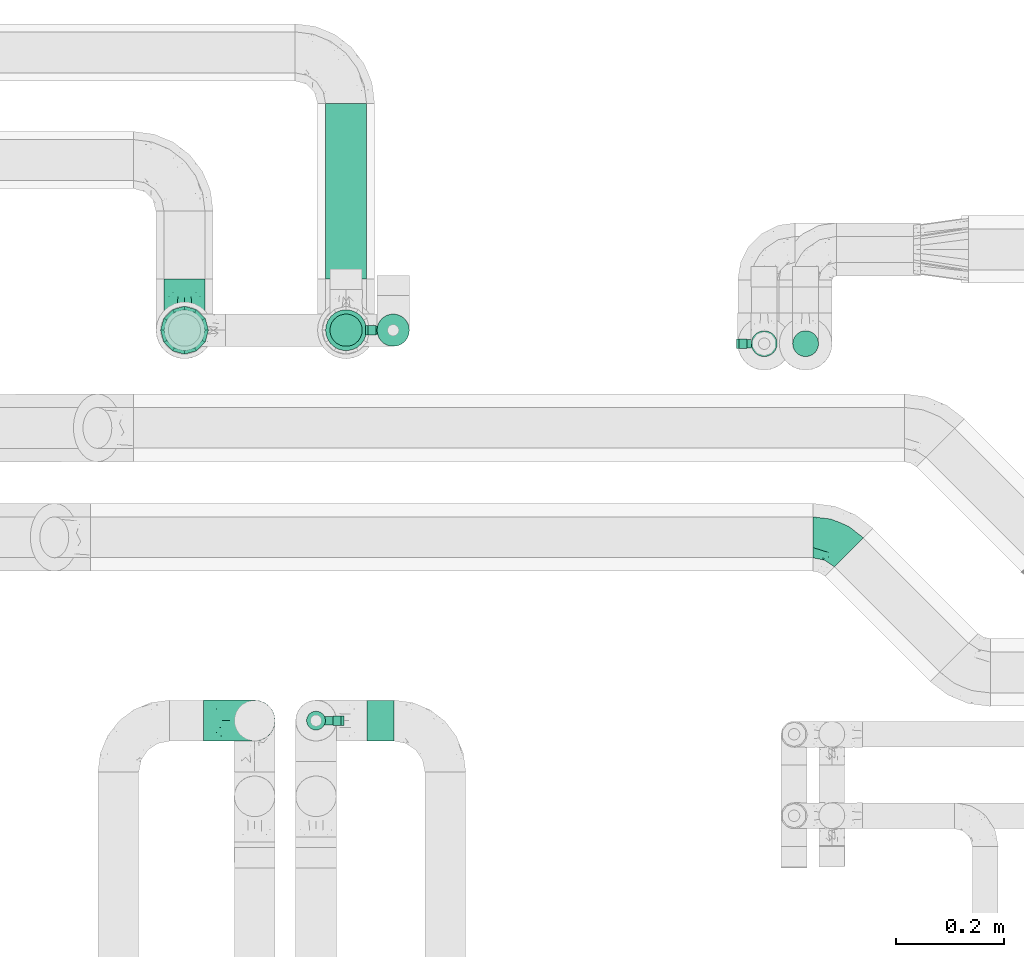
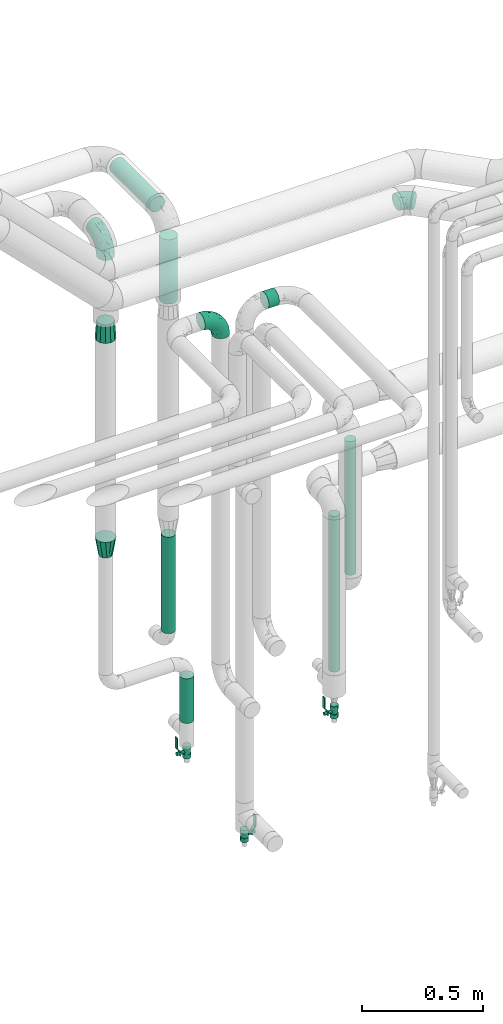
# One storey, part 680 of 824: 7 flow segments, 5 flow fittings, 3 flow controllers.
"""IFC2X3 building model written with IfcOpenShell, lengths in millimetres."""

from ifc_helpers import new_model, entity, si_unit, converted_unit, derived_unit, direction, frame, origin, origin_2d_with_axis, place, context, subcontext, project, spatial, polyline, circle, outline, extrude, faceted_brep, source, transform, mapped, material, material_list, type_object, type_shapes, element, save


model = new_model("IFC2X3")

# Units and contexts
model_context = context("Model", 3, precision=0.01, world=origin(), true_north=direction((6.12303176911189e-17, 1.0)))
body_context = subcontext(model_context, "Body", "Model", "MODEL_VIEW")
ifc_project = project(units=[si_unit("LENGTHUNIT", "METRE", prefix="MILLI"), si_unit("AREAUNIT", "SQUARE_METRE"), si_unit("VOLUMEUNIT", "CUBIC_METRE"), converted_unit("PLANEANGLEUNIT", "DEGREE", entity("IfcRatioMeasure", 0.0174532925199433), si_unit("PLANEANGLEUNIT", "RADIAN"), dimensions=[0, 0, 0, 0, 0, 0, 0]), si_unit("MASSUNIT", "GRAM", prefix="KILO"), derived_unit("MASSDENSITYUNIT", [(si_unit("MASSUNIT", "GRAM", prefix="KILO"), 1), (si_unit("LENGTHUNIT", "METRE"), -3)]), derived_unit("MOMENTOFINERTIAUNIT", [(si_unit("LENGTHUNIT", "METRE"), 4)]), si_unit("TIMEUNIT", "SECOND"), si_unit("FREQUENCYUNIT", "HERTZ"), si_unit("THERMODYNAMICTEMPERATUREUNIT", "DEGREE_CELSIUS"), derived_unit("THERMALTRANSMITTANCEUNIT", [(si_unit("MASSUNIT", "GRAM", prefix="KILO"), 1), (si_unit("THERMODYNAMICTEMPERATUREUNIT", "KELVIN"), -1), (si_unit("TIMEUNIT", "SECOND"), -3)]), derived_unit("VOLUMETRICFLOWRATEUNIT", [(si_unit("LENGTHUNIT", "METRE"), 3), (si_unit("TIMEUNIT", "SECOND"), -1)]), derived_unit("MASSFLOWRATEUNIT", [(si_unit("MASSUNIT", "GRAM", prefix="KILO"), 1), (si_unit("TIMEUNIT", "SECOND"), -1)]), derived_unit("ROTATIONALFREQUENCYUNIT", [(si_unit("TIMEUNIT", "SECOND"), -1)]), si_unit("ELECTRICCURRENTUNIT", "AMPERE"), si_unit("ELECTRICVOLTAGEUNIT", "VOLT"), si_unit("POWERUNIT", "WATT"), si_unit("FORCEUNIT", "NEWTON", prefix="KILO"), si_unit("ILLUMINANCEUNIT", "LUX"), si_unit("LUMINOUSFLUXUNIT", "LUMEN"), si_unit("LUMINOUSINTENSITYUNIT", "CANDELA"), derived_unit("USERDEFINED", [(si_unit("MASSUNIT", "GRAM", prefix="KILO"), -1), (si_unit("LENGTHUNIT", "METRE"), -2), (si_unit("TIMEUNIT", "SECOND"), 3), (si_unit("LUMINOUSFLUXUNIT", "LUMEN"), 1)]), derived_unit("LINEARVELOCITYUNIT", [(si_unit("LENGTHUNIT", "METRE"), 1), (si_unit("TIMEUNIT", "SECOND"), -1)]), si_unit("PRESSUREUNIT", "PASCAL"), derived_unit("USERDEFINED", [(si_unit("LENGTHUNIT", "METRE"), -2), (si_unit("MASSUNIT", "GRAM", prefix="KILO"), 1), (si_unit("TIMEUNIT", "SECOND"), -2)]), derived_unit("LINEARFORCEUNIT", [(si_unit("MASSUNIT", "GRAM", prefix="KILO"), 1), (si_unit("LENGTHUNIT", "METRE"), 1), (si_unit("TIMEUNIT", "SECOND"), -2), (si_unit("LENGTHUNIT", "METRE"), -1)]), derived_unit("PLANARFORCEUNIT", [(si_unit("MASSUNIT", "GRAM", prefix="KILO"), 1), (si_unit("LENGTHUNIT", "METRE"), 1), (si_unit("TIMEUNIT", "SECOND"), -2), (si_unit("LENGTHUNIT", "METRE"), -2)])], contexts=[model_context])

# Site, building, storey
site_placement = place(None, origin())
site = spatial("IfcSite", under=ifc_project, at=site_placement, CompositionType="ELEMENT")
building_placement = place(site_placement, origin())
building = spatial("IfcBuilding", under=site, at=building_placement, CompositionType="ELEMENT")
storey_placement = place(building_placement, frame((0.0, 0.0, 28200.0)))
storey = spatial("IfcBuildingStorey", under=building, at=storey_placement, CompositionType="ELEMENT", Elevation=28200.0)

# Flow segments
pipe_segment_type_1 = type_object("IfcPipeSegmentType", PredefinedType="NOTDEFINED")
flow_segment_1_placement = place(storey_placement, frame((46768.22, 19086.22, 2960.4)))
element("IfcFlowSegment", 1, at=flow_segment_1_placement, inside=storey, type_object=pipe_segment_type_1, context=body_context, shape_type="SweptSolid", body=[
    extrude(circle(Radius=38.0, at=origin_2d_with_axis()), frame((39.6, 0.0, 39.6), z_axis=(0.0, 1.0, 0.0), x_axis=(-1.0, 0.0, 0.0)), (0.0, 0.0, 1.0), 326.0116),
])
flow_segment_2_placement = place(storey_placement, frame((46768.22, 18951.63, 2580.0)))
element("IfcFlowSegment", 2, at=flow_segment_2_placement, inside=storey, type_object=pipe_segment_type_1, context=body_context, shape_type="SweptSolid", body=[
    extrude(circle(Radius=38.0, at=origin_2d_with_axis()), frame((39.6, 39.6, 0.0)), (0.0, 0.0, 1.0), 325.000000000017),
])
pipe_segment_type_2 = type_object("IfcPipeSegmentType", PredefinedType="NOTDEFINED")
flow_segment_3_placement = place(storey_placement, frame((46847.07, 18226.89, 2960.65)))
element("IfcFlowSegment", 3, at=flow_segment_3_placement, inside=storey, type_object=pipe_segment_type_2, context=body_context, shape_type="SweptSolid", body=[
    extrude(circle(Radius=37.75, at=origin_2d_with_axis()), frame((0.0, 39.35, 39.35), z_axis=(1.0, 0.0, 0.0), x_axis=(0.0, 1.0, 0.0)), (0.0, 0.0, 1.0), 50.000000000006),
])
flow_segment_4_placement = place(storey_placement, frame((47558.7, 18940.63, 457.0)))
element("IfcFlowSegment", 4, at=flow_segment_4_placement, inside=storey, type_object=pipe_segment_type_2, context=body_context, shape_type="SweptSolid", body=[
    extrude(circle(Radius=24.0, at=origin_2d_with_axis()), frame((25.6, 25.6, 0.0)), (0.0, 0.0, 1.0), 785.999999709128),
])
flow_segment_5_placement = place(storey_placement, frame((47635.58, 18940.63, 918.88)))
element("IfcFlowSegment", 5, at=flow_segment_5_placement, inside=storey, type_object=pipe_segment_type_2, context=body_context, shape_type="SweptSolid", body=[
    extrude(circle(Radius=24.0, at=origin_2d_with_axis()), frame((25.6, 25.6, 0.0), z_axis=(0.0, 0.0, 1.0), x_axis=(-1.0, 0.0, 0.0)), (0.0, 0.0, 1.0), 674.12499999997),
])
flow_segment_6_placement = place(storey_placement, frame((46776.22, 18959.63, 912.38)))
element("IfcFlowSegment", 6, at=flow_segment_6_placement, inside=storey, type_object=pipe_segment_type_2, context=body_context, shape_type="SweptSolid", body=[
    extrude(circle(Radius=30.0, at=origin_2d_with_axis()), frame((31.6, 31.6, 0.0), z_axis=(0.0, 0.0, 1.0), x_axis=(-1.0, 0.0, 0.0)), (0.0, 0.0, 1.0), 486.500000000002),
])
flow_segment_7_placement = place(storey_placement, frame((46863.72, 18959.63, 429.0)))
element("IfcFlowSegment", 7, at=flow_segment_7_placement, inside=storey, type_object=pipe_segment_type_2, context=body_context, shape_type="SweptSolid", body=[
    extrude(circle(Radius=30.0, at=origin_2d_with_axis()), frame((31.6, 31.6, 0.0)), (0.0, 0.0, 1.0), 224.999999999888),
])

# Flow controllers
ifc_material = material()
ifc_material_list = material_list([ifc_material, ifc_material, ifc_material, ifc_material, ifc_material])
valve_type = type_object("IfcValveType", PredefinedType="NOTDEFINED", material=ifc_material_list)
shared_shape_1 = source(origin(), body_context, "Body", "SweptSolid", [
    extrude(circle(Radius=17.5, at=origin_2d_with_axis()), frame((-30.5, 0.0, 0.0), z_axis=(1.0, 0.0, 0.0), x_axis=(0.0, 1.0, 0.0)), (0.0, 0.0, 1.0), 20.3333333333333),
    extrude(circle(Radius=16.0, at=origin_2d_with_axis()), frame((-10.17, 0.0, 0.0), z_axis=(1.0, 0.0, 0.0), x_axis=(0.0, 1.0, 0.0)), (0.0, 0.0, 1.0), 20.3333333333333),
    extrude(circle(Radius=17.5, at=origin_2d_with_axis()), frame((10.17, 0.0, 0.0), z_axis=(1.0, 0.0, 0.0), x_axis=(0.0, 1.0, 0.0)), (0.0, 0.0, 1.0), 20.3333333333333),
    extrude(outline(polyline([(-38.75, -5.0), (-38.75, -10.0), (-17.92, -10.0), (2.08, 5.0), (56.25, 5.0), (56.25, 10.0), (0.42, 10.0), (-19.58, -5.0), (-38.75, -5.0)])), frame((28.75, -8.75, 41.5), z_axis=(0.0, -1.0, 0.0), x_axis=(1.0, 0.0, 0.0)), (0.0, 0.0, -1.0), 17.5),
    extrude(circle(Radius=8.0, at=origin_2d_with_axis()), origin(), (0.0, 0.0, 1.0), 49.0),
])
type_shapes(valve_type, [shared_shape_1])
for number, where, z_axis, x_axis in (
    (8, (47584.3, 18966.22, 247.5), (-1.0, 0.0, 0.0), (0.0, 0.0, 1.0)),
    (9, (46895.32, 18991.22, 270.5), (-1.0, 0.0, 0.0), (0.0, 0.0, 1.0)),
    (10, (46752.07, 18266.24, 338.5), (1.0, 0.0, 0.0), (0.0, 0.0, 1.0)),
):
    element("IfcFlowController", number, at=place(storey_placement, frame(where, z_axis=z_axis, x_axis=x_axis)), inside=storey, type_object=valve_type, material=ifc_material, context=body_context, shape_type="MappedRepresentation", body=[
        mapped(shared_shape_1, transform((0.0, 0.0, 0.0), scale=1.0)),
    ])

# Flow fittings
pipe_fitting_type_1 = type_object("IfcPipeFittingType", PredefinedType="NOTDEFINED", material=ifc_material)
shared_shape_2 = source(origin(), body_context, "Body", "Brep", [
    faceted_brep([(-95.0, 19.02, -32.95), (-95.0, 9.85, -36.75), (-95.0, 0.0, -38.05), (-95.0, -9.85, -36.75), (-95.0, -19.03, -32.95), (-95.0, -26.91, -26.91), (-95.0, -32.95, -19.03), (-95.0, -36.75, -9.85), (-95.0, -38.05, 0.0), (-95.0, -36.75, 9.85), (-95.0, -32.95, 19.02), (-95.0, -26.91, 26.91), (-95.0, -19.03, 32.95), (-95.0, -9.85, 36.75), (-95.0, 0.0, 38.05), (-95.0, 9.85, 36.75), (-95.0, 19.02, 32.95), (-95.0, 26.91, 26.91), (-95.0, 32.95, 19.02), (-95.0, 36.75, 9.85), (-95.0, 38.05, 0.0), (-95.0, 36.75, -9.85), (-95.0, 32.95, -19.03), (-95.0, 26.91, -26.91), (0.0, 95.0, -38.05), (-9.85, 95.0, -36.75), (-19.02, 95.0, -32.95), (-26.91, 95.0, -26.91), (-32.95, 95.0, -19.03), (-36.75, 95.0, -9.85), (-38.05, 95.0, 0.0), (-36.75, 95.0, 9.85), (-32.95, 95.0, 19.02), (-26.91, 95.0, 26.91), (-19.02, 95.0, 32.95), (-9.85, 95.0, 36.75), (0.0, 95.0, 38.05), (9.85, 95.0, 36.75), (19.03, 95.0, 32.95), (26.91, 95.0, 26.91), (32.95, 95.0, 19.02), (36.75, 95.0, 9.85), (38.05, 95.0, 0.0), (36.75, 95.0, -9.85), (32.95, 95.0, -19.03), (26.91, 95.0, -26.91), (19.03, 95.0, -32.95), (9.85, 95.0, -36.75), (-7.99, -4.96, 6.3), (-0.92, 0.92, 0.0), (4.62, 8.1, 8.01), (-76.19, -35.57, 0.0), (-64.32, -32.32, 12.43), (20.51, 62.45, 28.68), (-60.56, -33.52, 0.0), (-70.4, -13.47, 34.42), (-39.61, -5.88, 32.32), (-49.6, 2.07, 37.1), (-70.34, -28.81, 21.71), (14.64, 40.81, 26.5), (5.88, 39.61, 32.32), (3.59, 20.77, 25.31), (-40.45, 68.06, 16.75), (-62.45, -20.51, 28.68), (-44.52, -26.87, 0.0), (-28.47, -20.22, 0.0), (-26.43, -17.83, 8.75), (-76.1, 39.63, 10.76), (-72.74, 37.58, 18.19), (-60.35, 46.18, 14.61), (-13.4, 13.4, 32.12), (-20.77, -3.59, 25.31), (-14.66, 81.47, 35.56), (-6.22, 71.26, 37.92), (-57.5, 42.48, 22.79), (-15.0, 34.74, 37.7), (-27.1, 12.08, 36.05), (-9.2, 28.81, 35.63), (-79.98, 23.7, 30.95), (-73.68, -4.3, 37.48), (-30.74, 21.67, 37.97), (-62.36, 47.59, 6.79), (-72.71, 32.83, 24.69), (-67.42, 7.02, 37.95), (-32.13, 75.27, 24.51), (-43.46, 51.47, 26.26), (-24.98, 73.15, 31.29), (20.59, 41.28, 19.85), (7.79, 16.09, 15.86), (-73.21, 42.39, 0.0), (-54.73, 54.73, 0.0), (-73.44, 15.79, 35.79), (-5.94, 4.32, 20.43), (28.81, 70.34, 21.71), (32.32, 64.32, 12.43), (-53.59, 26.2, 35.09), (-52.02, 19.31, 37.21), (21.38, 33.53, 10.34), (26.87, 44.52, 0.0), (-48.28, 12.14, 38.05), (4.3, 73.68, 37.48), (-44.08, -25.52, 12.79), (-41.28, -20.59, 19.85), (35.57, 76.19, 0.0), (-47.26, 54.3, 20.18), (-47.4, 61.99, 8.58), (-42.39, 73.21, 0.0), (-39.67, 78.86, 7.21), (-45.69, 36.84, 33.11), (-32.83, 50.13, 33.35), (13.47, 70.4, 34.42), (-18.25, 63.73, 36.07), (-40.63, -13.75, 27.22), (-16.63, 46.37, 37.95), (-53.47, 38.79, 28.59), (-26.07, 48.54, 36.15), (-34.51, 34.51, 36.86), (-2.07, 49.6, 37.1), (-22.79, -10.49, 19.23), (-61.73, 28.67, 31.87), (9.65, 14.7, 0.0), (20.22, 28.47, 0.0), (33.52, 60.56, 0.0), (-11.42, -5.44, 13.25), (-14.7, -9.65, 0.0), (-81.47, 14.66, -35.56), (-62.45, -20.51, -28.68), (-71.26, 6.22, -37.92), (-75.27, 32.13, -24.51), (-73.15, 24.98, -31.29), (13.47, 70.4, -34.42), (5.88, 39.61, -32.32), (-2.07, 49.6, -37.1), (-78.86, 39.67, -7.21), (-70.4, -13.47, -34.42), (-39.61, -5.88, -32.32), (-61.99, 47.4, -8.58), (32.32, 64.32, -12.43), (28.81, 70.34, -21.71), (-63.73, 18.25, -36.07), (-50.13, 32.83, -33.35), (4.3, 73.68, -37.48), (-7.02, 67.42, -37.95), (-39.63, 76.1, -10.76), (-46.18, 60.35, -14.61), (-47.59, 62.36, -6.79), (-64.32, -32.32, -12.43), (-26.2, 53.59, -35.09), (-15.79, 73.44, -35.79), (-19.31, 52.02, -37.21), (-37.58, 72.74, -18.19), (-70.34, -28.81, -21.71), (-42.48, 57.5, -22.79), (-38.79, 53.47, -28.59), (-51.47, 43.46, -26.26), (-32.83, 72.71, -24.69), (-46.37, 16.63, -37.95), (-73.68, -4.3, -37.48), (-41.28, -20.59, -19.85), (-44.08, -25.52, -12.79), (13.75, 40.63, -27.22), (20.51, 62.45, -28.68), (-68.06, 40.45, -16.75), (-54.3, 47.26, -20.18), (-12.14, 48.28, -38.05), (-21.67, 30.74, -37.97), (-36.84, 45.69, -33.11), (-11.42, -5.44, -13.25), (7.79, 16.09, -15.86), (4.62, 8.1, -8.01), (-23.7, 79.98, -30.95), (-26.43, -17.83, -8.75), (-7.99, -4.96, -6.3), (-40.81, -14.64, -26.5), (-20.77, -3.59, -25.31), (-34.74, 15.0, -37.7), (-12.08, 27.1, -36.05), (-28.81, 9.2, -35.63), (-22.79, -10.49, -19.23), (21.38, 33.53, -10.34), (20.59, 41.28, -19.85), (-48.54, 26.07, -36.15), (-49.6, 2.07, -37.1), (-13.4, 13.4, -32.12), (3.59, 20.77, -25.31), (-28.67, 61.73, -31.87), (-34.51, 34.51, -36.86), (-5.94, 4.32, -20.43)], [[[0, 1, 2, 3, 4, 5, 6, 7, 8, 9, 10, 11, 12, 13, 14, 15, 16, 17, 18, 19, 20, 21, 22, 23]], [[24, 25, 26, 27, 28, 29, 30, 31, 32, 33, 34, 35, 36, 37, 38, 39, 40, 41, 42, 43, 44, 45, 46, 47]], [[48, 49, 50]], [[51, 52, 9]], [[53, 39, 38]], [[9, 52, 10]], [[54, 52, 51]], [[55, 56, 57]], [[11, 10, 58]], [[59, 60, 61]], [[32, 31, 62]], [[63, 12, 11]], [[63, 55, 12]], [[64, 65, 66]], [[67, 68, 69]], [[70, 56, 71]], [[35, 72, 73]], [[69, 68, 74]], [[75, 76, 77]], [[16, 78, 17]], [[13, 79, 14]], [[76, 75, 80]], [[67, 69, 81]], [[18, 17, 82]], [[14, 79, 83]], [[20, 19, 67]], [[84, 85, 86]], [[87, 61, 88]], [[89, 81, 90]], [[18, 82, 68]], [[15, 91, 16]], [[14, 83, 15]], [[71, 92, 61]], [[17, 78, 82]], [[93, 87, 94]], [[95, 91, 96]], [[97, 98, 94]], [[86, 72, 34]], [[96, 99, 80]], [[37, 36, 100]], [[40, 39, 93]], [[40, 94, 41]], [[64, 66, 101]], [[93, 94, 40]], [[58, 102, 63]], [[94, 103, 41]], [[94, 87, 97]], [[104, 69, 74]], [[34, 33, 86]], [[105, 69, 104]], [[52, 58, 10]], [[106, 107, 30]], [[108, 109, 85]], [[105, 106, 90]], [[53, 110, 60]], [[86, 111, 72]], [[86, 109, 111]], [[33, 84, 86]], [[12, 55, 13]], [[112, 56, 63]], [[110, 38, 37]], [[34, 72, 35]], [[36, 35, 73]], [[111, 113, 73]], [[105, 107, 106]], [[110, 53, 38]], [[74, 114, 85]], [[91, 15, 83]], [[105, 90, 81]], [[107, 62, 31]], [[33, 32, 84]], [[115, 109, 116]], [[111, 115, 113]], [[100, 73, 117]], [[56, 55, 63]], [[79, 55, 57]], [[102, 118, 112]], [[56, 70, 76]], [[100, 110, 37]], [[117, 77, 60]], [[117, 60, 110]], [[60, 70, 61]], [[58, 52, 101]], [[63, 11, 58]], [[39, 53, 93]], [[87, 93, 53]], [[96, 91, 83]], [[78, 91, 119]], [[32, 62, 84]], [[84, 62, 104]], [[86, 85, 109]], [[85, 114, 108]], [[80, 113, 116]], [[117, 73, 113]], [[80, 116, 96]], [[80, 57, 76]], [[71, 112, 118]], [[61, 87, 59]], [[62, 107, 105]], [[97, 120, 121]], [[70, 71, 61]], [[71, 118, 92]], [[73, 100, 36]], [[110, 100, 117]], [[55, 79, 13]], [[83, 79, 57]], [[96, 83, 99]], [[116, 108, 95]], [[50, 97, 88]], [[97, 87, 88]], [[50, 49, 120]], [[122, 94, 98]], [[89, 20, 67]], [[105, 81, 69]], [[89, 67, 81]], [[68, 19, 18]], [[68, 67, 19]], [[74, 68, 82]], [[114, 82, 119]], [[74, 85, 104]], [[82, 114, 74]], [[114, 119, 108]], [[95, 108, 119]], [[116, 109, 108]], [[123, 48, 50]], [[97, 50, 120]], [[123, 50, 88]], [[91, 95, 119]], [[116, 95, 96]], [[84, 104, 85]], [[104, 62, 105]], [[83, 57, 99]], [[57, 80, 99]], [[66, 48, 123]], [[66, 124, 48]], [[118, 66, 123]], [[124, 66, 65]], [[66, 118, 101]], [[54, 64, 52]], [[124, 49, 48]], [[30, 107, 31]], [[91, 78, 16]], [[82, 78, 119]], [[56, 76, 57]], [[77, 76, 70]], [[60, 77, 70]], [[77, 117, 75]], [[117, 113, 75]], [[113, 80, 75]], [[9, 8, 51]], [[103, 94, 122]], [[103, 42, 41]], [[73, 72, 111]], [[113, 115, 116]], [[111, 109, 115]], [[102, 112, 63]], [[71, 56, 112]], [[118, 102, 101]], [[92, 123, 88]], [[123, 92, 118]], [[61, 92, 88]], [[87, 53, 59]], [[60, 59, 53]], [[97, 121, 98]], [[58, 101, 102]], [[64, 101, 52]], [[125, 1, 0]], [[126, 5, 4]], [[2, 1, 127]], [[1, 125, 127]], [[128, 129, 23]], [[130, 131, 132]], [[89, 133, 20]], [[126, 134, 135]], [[136, 89, 90]], [[137, 138, 44]], [[139, 129, 140]], [[24, 141, 142]], [[143, 144, 145]], [[125, 129, 139]], [[6, 146, 7]], [[147, 148, 149]], [[146, 51, 7]], [[143, 150, 144]], [[146, 6, 151]], [[152, 153, 154]], [[126, 4, 134]], [[0, 23, 129]], [[28, 155, 150]], [[43, 42, 103]], [[54, 146, 64]], [[139, 156, 127]], [[157, 3, 2]], [[151, 158, 159]], [[160, 131, 161]], [[22, 21, 162]], [[136, 144, 163]], [[149, 164, 165]], [[24, 142, 25]], [[166, 140, 154]], [[154, 129, 128]], [[143, 30, 29]], [[167, 168, 169]], [[155, 28, 27]], [[26, 170, 27]], [[171, 167, 172]], [[26, 25, 148]], [[27, 170, 155]], [[173, 135, 174]], [[144, 150, 152]], [[175, 176, 177]], [[24, 47, 141]], [[45, 161, 46]], [[148, 25, 142]], [[176, 175, 165]], [[64, 159, 171]], [[138, 45, 44]], [[130, 46, 161]], [[137, 44, 43]], [[178, 159, 158]], [[137, 103, 122]], [[163, 144, 152]], [[136, 133, 89]], [[103, 137, 43]], [[6, 5, 151]], [[178, 158, 173]], [[134, 4, 3]], [[178, 173, 174]], [[137, 98, 179]], [[145, 90, 106]], [[138, 180, 161]], [[46, 130, 47]], [[136, 90, 145]], [[133, 162, 21]], [[23, 22, 128]], [[139, 140, 181]], [[139, 181, 156]], [[157, 127, 182]], [[157, 134, 3]], [[182, 177, 135]], [[182, 135, 134]], [[135, 183, 174]], [[131, 130, 161]], [[141, 130, 132]], [[160, 180, 184]], [[131, 183, 176]], [[5, 126, 151]], [[158, 151, 126]], [[180, 138, 137]], [[161, 45, 138]], [[149, 148, 142]], [[170, 148, 185]], [[22, 162, 128]], [[128, 162, 163]], [[129, 154, 140]], [[154, 153, 166]], [[165, 156, 186]], [[182, 127, 156]], [[165, 186, 149]], [[165, 132, 176]], [[131, 184, 183]], [[187, 167, 178]], [[184, 168, 187]], [[167, 169, 172]], [[184, 180, 168]], [[174, 183, 184]], [[127, 157, 2]], [[134, 157, 182]], [[130, 141, 47]], [[142, 141, 132]], [[149, 142, 164]], [[186, 166, 147]], [[180, 179, 168]], [[169, 179, 120]], [[137, 179, 180]], [[179, 121, 120]], [[106, 30, 143]], [[136, 145, 144]], [[106, 143, 145]], [[150, 29, 28]], [[150, 143, 29]], [[152, 150, 155]], [[153, 155, 185]], [[152, 154, 163]], [[155, 153, 152]], [[153, 185, 166]], [[147, 166, 185]], [[186, 140, 166]], [[169, 120, 49]], [[169, 49, 172]], [[179, 169, 168]], [[148, 147, 185]], [[186, 147, 149]], [[128, 163, 154]], [[163, 162, 136]], [[142, 132, 164]], [[132, 165, 164]], [[171, 124, 65]], [[124, 171, 172]], [[64, 146, 159]], [[171, 159, 178]], [[171, 65, 64]], [[172, 49, 124]], [[162, 133, 136]], [[20, 133, 21]], [[148, 170, 26]], [[155, 170, 185]], [[131, 176, 132]], [[177, 176, 183]], [[135, 177, 183]], [[177, 182, 175]], [[182, 156, 175]], [[156, 165, 175]], [[51, 146, 54]], [[51, 8, 7]], [[129, 125, 0]], [[127, 125, 139]], [[140, 186, 181]], [[156, 181, 186]], [[158, 126, 173]], [[135, 173, 126]], [[187, 178, 174]], [[171, 178, 167]], [[184, 187, 174]], [[167, 187, 168]], [[180, 160, 161]], [[184, 131, 160]], [[98, 137, 122]], [[98, 121, 179]], [[151, 159, 146]]]),
])
type_shapes(pipe_fitting_type_1, [shared_shape_2])
for number, where, z_axis, x_axis in (
    (11, (46507.82, 18991.22, 3000.0), (1.0, 0.0, 0.0), (0.0, -1.0, 0.0)),
    (12, (46638.03, 18266.24, 3000.0), (0.0, -1.0, 0.0), (0.0, 0.0, 1.0)),
):
    element("IfcFlowFitting", number, at=place(storey_placement, frame(where, z_axis=z_axis, x_axis=x_axis)), inside=storey, type_object=pipe_fitting_type_1, material=ifc_material, context=body_context, shape_type="MappedRepresentation", body=[
        mapped(shared_shape_2, transform((0.0, 0.0, 0.0), scale=1.0)),
    ])
pipe_fitting_type_2 = type_object("IfcPipeFittingType", PredefinedType="NOTDEFINED", material=ifc_material)
shared_shape_3 = source(origin(), body_context, "Body", "Brep", [
    faceted_brep([(-39.35, 19.02, -32.95), (-39.35, 9.85, -36.75), (-39.35, 0.0, -38.05), (-39.35, -9.85, -36.75), (-39.35, -19.03, -32.95), (-39.35, -26.91, -26.91), (-39.35, -32.95, -19.03), (-39.35, -36.75, -9.85), (-39.35, -38.05, 0.0), (-39.35, -36.75, 9.85), (-39.35, -32.95, 19.02), (-39.35, -26.91, 26.91), (-39.35, -19.03, 32.95), (-39.35, -9.85, 36.75), (-39.35, 0.0, 38.05), (-39.35, 9.85, 36.75), (-39.35, 19.02, 32.95), (-39.35, 26.91, 26.91), (-39.35, 32.95, 19.02), (-39.35, 36.75, 9.85), (-39.35, 38.05, 0.0), (-39.35, 36.75, -9.85), (-39.35, 32.95, -19.03), (-39.35, 26.91, -26.91), (27.82, 27.82, -38.05), (20.86, 34.79, -36.75), (14.37, 41.28, -32.95), (8.8, 46.85, -26.91), (4.52, 51.13, -19.03), (1.84, 53.81, -9.85), (0.92, 54.73, 0.0), (1.84, 53.81, 9.85), (4.52, 51.13, 19.02), (8.8, 46.85, 26.91), (14.37, 41.28, 32.95), (20.86, 34.79, 36.75), (27.82, 27.82, 38.05), (34.79, 20.86, 36.75), (41.28, 14.37, 32.95), (46.85, 8.8, 26.91), (51.13, 4.52, 19.02), (53.81, 1.84, 9.85), (54.73, 0.92, 0.0), (53.81, 1.84, -9.85), (51.13, 4.52, -19.03), (46.85, 8.8, -26.91), (41.28, 14.37, -32.95), (34.79, 20.86, -36.75), (-16.48, -28.6, 22.48), (-9.83, -32.19, 13.52), (8.97, -21.66, 21.67), (-20.54, -35.57, 0.0), (-4.91, -33.52, 0.0), (-13.54, -34.93, 6.65), (-11.41, -20.66, 29.54), (31.88, -8.57, 22.48), (-19.69, -13.48, 34.86), (3.15, -7.61, 34.49), (12.7, 20.76, 37.8), (-14.37, -2.8, 37.58), (-4.35, 10.49, 37.89), (-23.66, 5.7, 37.8), (22.68, -6.54, 29.54), (23.46, 4.39, 34.86), (-17.67, 16.65, 35.5), (-11.48, 27.71, 30.93), (-5.05, 36.47, 26.65), (11.57, -24.66, 14.82), (11.29, -27.26, 7.35), (-19.91, 32.6, 23.86), (-16.29, 39.33, 15.52), (34.27, -15.12, 6.65), (39.68, -10.63, 0.0), (-13.09, 43.52, 7.94), (12.14, 8.18, 37.58), (29.72, -15.81, 13.52), (2.92, 25.68, 35.46), (5.55, -13.39, 30.82), (-17.56, 42.39, 0.0), (-7.75, 40.18, 21.01), (11.13, -26.87, 0.0), (27.17, -20.22, 0.0), (-14.37, -2.8, -37.58), (-13.54, -34.93, -6.65), (11.26, -27.2, -7.7), (0.72, 24.27, -35.5), (-23.66, 5.7, -37.8), (-21.52, 40.03, -7.94), (-16.29, 39.33, -15.52), (22.68, -6.54, -29.54), (-22.21, 29.36, -26.65), (29.72, -15.81, -13.52), (-22.93, 33.89, -21.01), (-8.97, 37.13, -23.86), (12.14, 8.18, -37.58), (-20.22, 16.09, -35.46), (-9.83, -32.19, -13.52), (31.88, -8.57, -22.48), (-16.48, -28.6, -22.48), (8.97, -21.66, -21.67), (8.74, -25.75, -14.99), (-11.41, -20.66, -29.54), (5.55, -13.39, -30.82), (3.15, -7.61, -34.49), (-19.69, -13.48, -34.86), (-11.48, 27.71, -30.93), (34.27, -15.12, -6.65), (12.7, 20.76, -37.8), (23.46, 4.39, -34.86), (-4.35, 10.49, -37.89)], [[[0, 1, 2, 3, 4, 5, 6, 7, 8, 9, 10, 11, 12, 13, 14, 15, 16, 17, 18, 19, 20, 21, 22, 23]], [[24, 25, 26, 27, 28, 29, 30, 31, 32, 33, 34, 35, 36, 37, 38, 39, 40, 41, 42, 43, 44, 45, 46, 47]], [[48, 49, 50]], [[51, 52, 53]], [[12, 11, 54]], [[40, 39, 55]], [[56, 54, 57]], [[48, 11, 10]], [[36, 35, 58]], [[13, 12, 56]], [[59, 60, 61]], [[14, 13, 59]], [[62, 55, 39]], [[38, 37, 63]], [[61, 15, 14]], [[16, 64, 65]], [[9, 51, 53]], [[33, 66, 34]], [[67, 49, 68]], [[65, 17, 16]], [[18, 17, 69]], [[18, 69, 70]], [[19, 18, 70]], [[41, 71, 72]], [[73, 20, 19]], [[52, 68, 53]], [[49, 53, 68]], [[16, 15, 64]], [[36, 58, 74]], [[39, 38, 62]], [[57, 74, 59]], [[74, 37, 36]], [[66, 69, 65]], [[75, 40, 55]], [[60, 58, 76]], [[62, 38, 63]], [[17, 65, 69]], [[71, 41, 75]], [[49, 48, 10]], [[61, 64, 15]], [[77, 50, 62]], [[19, 70, 73]], [[10, 9, 49]], [[78, 73, 30]], [[48, 54, 11]], [[31, 73, 70]], [[57, 63, 74]], [[69, 66, 79]], [[55, 62, 50]], [[79, 70, 69]], [[56, 59, 13]], [[35, 34, 76]], [[76, 65, 64]], [[54, 77, 57]], [[60, 59, 74]], [[75, 41, 40]], [[54, 48, 50]], [[32, 31, 70]], [[75, 55, 50]], [[65, 76, 34]], [[60, 76, 64]], [[54, 56, 12]], [[59, 56, 57]], [[74, 63, 37]], [[62, 63, 57]], [[9, 8, 51]], [[68, 52, 80, 81]], [[9, 53, 49]], [[71, 68, 81]], [[68, 75, 67]], [[72, 71, 81]], [[72, 42, 41]], [[68, 71, 75]], [[59, 61, 14]], [[64, 61, 60]], [[76, 58, 35]], [[74, 58, 60]], [[30, 73, 31]], [[73, 78, 20]], [[50, 77, 54]], [[62, 57, 77]], [[34, 66, 65]], [[79, 33, 32]], [[33, 79, 66]], [[32, 70, 79]], [[75, 50, 67]], [[49, 67, 50]], [[3, 2, 82]], [[52, 83, 84]], [[26, 25, 85]], [[2, 1, 86]], [[21, 87, 88]], [[46, 45, 89]], [[0, 23, 90]], [[44, 43, 91]], [[92, 88, 93]], [[24, 47, 94]], [[29, 28, 88]], [[1, 0, 95]], [[83, 7, 96]], [[91, 97, 44]], [[98, 99, 100]], [[98, 96, 6]], [[5, 4, 101]], [[89, 102, 103]], [[7, 6, 96]], [[5, 98, 6]], [[104, 4, 3]], [[90, 93, 105]], [[101, 98, 5]], [[28, 27, 93]], [[20, 78, 87]], [[27, 105, 93]], [[30, 29, 87]], [[102, 99, 101]], [[105, 85, 95]], [[88, 22, 21]], [[28, 93, 88]], [[104, 101, 4]], [[85, 105, 26]], [[90, 92, 93]], [[86, 82, 2]], [[27, 26, 105]], [[43, 72, 106]], [[107, 25, 24]], [[108, 47, 46]], [[7, 83, 51]], [[44, 97, 45]], [[103, 108, 89]], [[97, 89, 45]], [[109, 107, 94]], [[99, 97, 91]], [[109, 94, 82]], [[106, 72, 81]], [[108, 94, 47]], [[103, 104, 82]], [[83, 96, 84]], [[103, 82, 94]], [[100, 91, 84]], [[107, 85, 25]], [[29, 88, 87]], [[109, 86, 95]], [[98, 101, 99]], [[89, 97, 99]], [[105, 95, 0]], [[109, 95, 85]], [[82, 104, 3]], [[101, 104, 103]], [[89, 108, 46]], [[94, 108, 103]], [[51, 83, 52]], [[51, 8, 7]], [[100, 84, 96]], [[106, 84, 91]], [[84, 81, 80, 52]], [[43, 42, 72]], [[84, 106, 81]], [[43, 106, 91]], [[95, 86, 1]], [[82, 86, 109]], [[94, 107, 24]], [[85, 107, 109]], [[20, 87, 21]], [[87, 78, 30]], [[99, 102, 89]], [[101, 103, 102]], [[0, 90, 105]], [[92, 23, 22]], [[23, 92, 90]], [[22, 88, 92]], [[98, 100, 96]], [[91, 100, 99]]]),
])
type_shapes(pipe_fitting_type_2, [shared_shape_3])
flow_fitting_1_placement = place(storey_placement, frame((47713.82, 18606.7, 3000.0), z_axis=(0.0, 0.0, 1.0), x_axis=(-0.707106781186513, 0.707106781186582, 0.0)))
element("IfcFlowFitting", 13, at=flow_fitting_1_placement, inside=storey, type_object=pipe_fitting_type_2, material=ifc_material, context=body_context, shape_type="MappedRepresentation", body=[
    mapped(shared_shape_3, transform((0.0, 0.0, 0.0), scale=1.0)),
])
pipe_fitting_type_3 = type_object("IfcPipeFittingType", PredefinedType="NOTDEFINED", material=ifc_material)
shared_shape_4 = source(origin(), body_context, "Body", "Brep", [
    faceted_brep([(89.0, -44.45, 0.0), (89.0, -42.1, -8.76), (89.0, -38.49, -22.22), (89.0, -30.36, -30.36), (89.0, -22.23, -38.49), (89.0, -11.11, -41.47), (89.0, 0.0, -44.45), (89.0, 11.11, -41.47), (89.0, 22.22, -38.49), (89.0, 30.36, -30.36), (89.0, 38.49, -22.22), (89.0, 42.1, -8.76), (89.0, 44.45, 0.0), (89.0, 42.1, 8.76), (89.0, 38.49, 22.23), (89.0, 30.36, 30.36), (89.0, 22.22, 38.49), (89.0, 11.11, 41.47), (89.0, 0.0, 44.45), (89.0, -11.11, 41.47), (89.0, -22.23, 38.49), (89.0, -30.36, 30.36), (89.0, -38.49, 22.23), (89.0, -42.1, 8.76), (0.0, 30.15, 0.0), (0.0, 27.27, -8.86), (0.0, 24.39, -17.72), (0.0, 16.85, -23.2), (0.0, 9.32, -28.67), (0.0, 0.0, -28.67), (0.0, -9.32, -28.67), (0.0, -16.85, -23.2), (0.0, -24.39, -17.72), (0.0, -27.27, -8.86), (0.0, -30.15, 0.0), (0.0, -27.27, 8.86), (0.0, -24.39, 17.72), (0.0, -16.85, 23.2), (0.0, -9.32, 28.67), (0.0, 0.0, 28.67), (0.0, 9.32, 28.67), (0.0, 16.85, 23.2), (0.0, 24.39, 17.72), (0.0, 27.27, 8.86)], [[[0, 1, 2, 3, 4, 5, 6, 7, 8, 9, 10, 11, 12, 13, 14, 15, 16, 17, 18, 19, 20, 21, 22, 23]], [[24, 25, 26, 27, 28, 29, 30, 31, 32, 33, 34, 35, 36, 37, 38, 39, 40, 41, 42, 43]], [[2, 33, 32]], [[28, 7, 29]], [[29, 5, 30]], [[24, 12, 11]], [[3, 32, 31]], [[34, 1, 0]], [[1, 34, 33]], [[8, 28, 27]], [[2, 1, 33]], [[31, 4, 3]], [[2, 32, 3]], [[11, 25, 24]], [[26, 10, 9]], [[10, 25, 11]], [[28, 8, 7]], [[27, 26, 9]], [[26, 25, 10]], [[31, 30, 4]], [[8, 27, 9]], [[29, 7, 6]], [[5, 29, 6]], [[5, 4, 30]], [[14, 43, 42]], [[38, 19, 39]], [[39, 17, 40]], [[34, 0, 23]], [[15, 42, 41]], [[24, 13, 12]], [[13, 24, 43]], [[20, 38, 37]], [[14, 13, 43]], [[41, 16, 15]], [[14, 42, 15]], [[23, 35, 34]], [[36, 22, 21]], [[22, 35, 23]], [[38, 20, 19]], [[37, 36, 21]], [[36, 35, 22]], [[41, 40, 16]], [[20, 37, 21]], [[39, 19, 18]], [[17, 39, 18]], [[17, 16, 40]]]),
])
type_shapes(pipe_fitting_type_3, [shared_shape_4])
flow_fitting_2_placement = place(storey_placement, frame((46507.82, 18991.22, 1398.88), z_axis=(0.0, 1.0, 0.0), x_axis=(0.0, 0.0, 1.0)))
element("IfcFlowFitting", 14, at=flow_fitting_2_placement, inside=storey, type_object=pipe_fitting_type_3, material=ifc_material, context=body_context, shape_type="MappedRepresentation", body=[
    mapped(shared_shape_4, transform((0.0, 0.0, 0.0), scale=1.0)),
])
pipe_fitting_type_4 = type_object("IfcPipeFittingType", PredefinedType="NOTDEFINED", material=ifc_material)
shared_shape_5 = source(origin(), body_context, "Body", "Brep", [
    faceted_brep([(89.0, 38.05, 0.0), (89.0, 35.5, 9.51), (89.0, 32.95, 19.03), (89.0, 25.99, 25.99), (89.0, 19.02, 32.95), (89.0, 9.51, 35.5), (89.0, 0.0, 38.05), (89.0, -9.51, 35.5), (89.0, -19.03, 32.95), (89.0, -25.99, 25.99), (89.0, -32.95, 19.03), (89.0, -35.5, 9.51), (89.0, -38.05, 0.0), (89.0, -35.5, -9.51), (89.0, -32.95, -19.02), (89.0, -25.99, -25.99), (89.0, -19.03, -32.95), (89.0, -9.51, -35.5), (89.0, 0.0, -38.05), (89.0, 9.51, -35.5), (89.0, 19.02, -32.95), (89.0, 25.99, -25.99), (89.0, 32.95, -19.03), (89.0, 35.5, -9.51), (0.0, -38.49, 22.22), (0.0, -30.36, 30.36), (0.0, -22.22, 38.49), (0.0, -11.11, 41.47), (0.0, 0.0, 44.45), (0.0, 11.11, 41.47), (0.0, 22.23, 38.49), (0.0, 30.36, 30.36), (0.0, 38.49, 22.22), (0.0, 41.96, 9.31), (0.0, 44.45, 0.0), (0.0, 41.47, -11.11), (0.0, 38.49, -22.23), (0.0, 30.36, -30.36), (0.0, 22.23, -38.49), (0.0, 11.11, -41.47), (0.0, 0.0, -44.45), (0.0, -11.11, -41.47), (0.0, -22.23, -38.49), (0.0, -30.36, -30.36), (0.0, -38.49, -22.23), (0.0, -41.96, -9.31), (0.0, -44.45, 0.0), (0.0, -41.47, 11.11)], [[[0, 1, 2, 3, 4, 5, 6, 7, 8, 9, 10, 11, 12, 13, 14, 15, 16, 17, 18, 19, 20, 21, 22, 23]], [[24, 25, 26, 27, 28, 29, 30, 31, 32, 33, 34, 35, 36, 37, 38, 39, 40, 41, 42, 43, 44, 45, 46, 47]], [[23, 22, 36, 35, 34, 0]], [[39, 38, 20, 19, 18, 40]], [[38, 37, 36, 22, 21, 20]], [[43, 42, 16, 15, 14, 44]], [[41, 40, 18, 17, 16, 42]], [[12, 46, 45, 44, 14, 13]], [[11, 10, 24, 47, 46, 12]], [[27, 26, 8, 7, 6, 28]], [[26, 25, 24, 10, 9, 8]], [[31, 30, 4, 3, 2, 32]], [[29, 28, 6, 5, 4, 30]], [[0, 34, 33, 32, 2, 1]]]),
])
type_shapes(pipe_fitting_type_4, [shared_shape_5])
flow_fitting_3_placement = place(storey_placement, frame((46507.82, 18991.22, 2491.0), z_axis=(0.0, 1.0, 0.0), x_axis=(0.0, 0.0, 1.0)))
element("IfcFlowFitting", 15, at=flow_fitting_3_placement, inside=storey, type_object=pipe_fitting_type_4, material=ifc_material, context=body_context, shape_type="MappedRepresentation", body=[
    mapped(shared_shape_5, transform((0.0, 0.0, 0.0), scale=1.0)),
])

save(model, "model.ifc")
